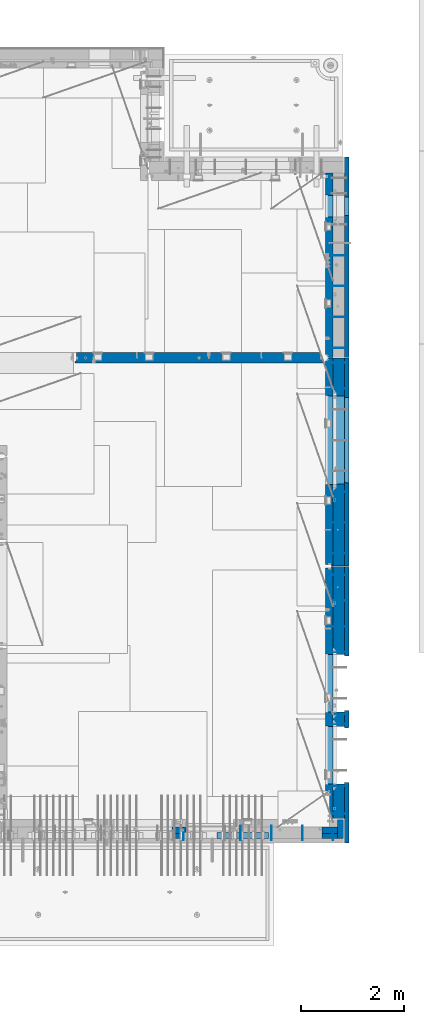
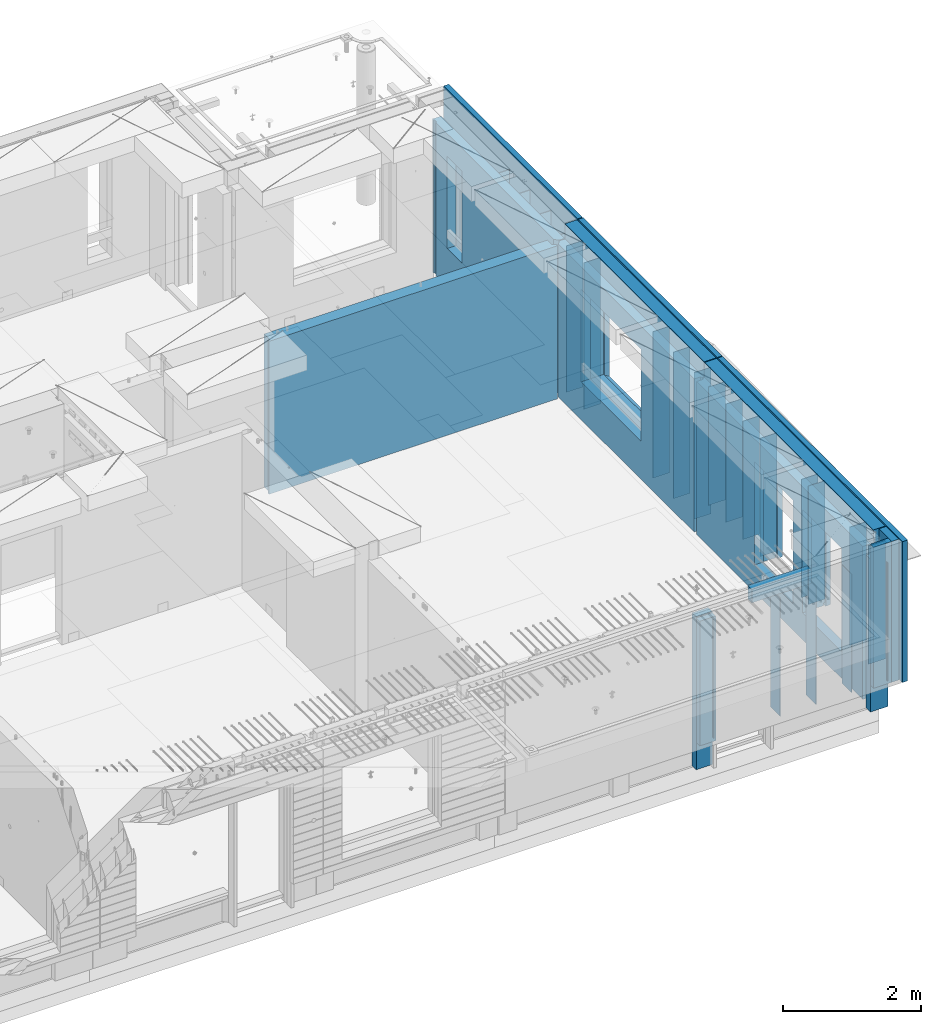
# One storey, part 221 of 325: 38 walls, 7 elements without a shape of their own.
"""IFC2X3 building model written with IfcOpenShell, lengths in millimetres."""

from ifc_helpers import new_model, si_unit, frame, origin_with_axes, place, context, subcontext, project, spatial, faceted_brep, material, type_object, element, aggregate, save


model = new_model("IFC2X3")

# Units and contexts
model_context = context("Model", 3, precision=1e-05, world=origin_with_axes())
body_context = subcontext(model_context, "Body", "Model", "MODEL_VIEW")
ifc_project = project(units=[si_unit("LENGTHUNIT", "METRE", prefix="MILLI"), si_unit("AREAUNIT", "SQUARE_METRE"), si_unit("VOLUMEUNIT", "CUBIC_METRE"), si_unit("MASSUNIT", "GRAM", prefix="KILO"), si_unit("TIMEUNIT", "SECOND"), si_unit("PLANEANGLEUNIT", "RADIAN"), si_unit("SOLIDANGLEUNIT", "STERADIAN"), si_unit("THERMODYNAMICTEMPERATUREUNIT", "DEGREE_CELSIUS"), si_unit("LUMINOUSINTENSITYUNIT", "LUMEN")], contexts=[model_context])

# Site, building, storey
site_placement = place(None, origin_with_axes())
site = spatial("IfcSite", under=ifc_project, at=site_placement, CompositionType="ELEMENT")
building_placement = place(site_placement, origin_with_axes())
building = spatial("IfcBuilding", under=site, at=building_placement, CompositionType="ELEMENT")
storey_placement = place(building_placement, origin_with_axes())
storey = spatial("IfcBuildingStorey", under=building, at=storey_placement, Name="1", CompositionType="ELEMENT", Elevation=0.0)

# Assembly, walls
assembly_1_placement = place(storey_placement, origin_with_axes())
assembly_1 = element("IfcElementAssembly", 1, at=assembly_1_placement, inside=storey, AssemblyPlace="NOTDEFINED", PredefinedType="REINFORCEMENT_UNIT")
ifc_material_1 = material(Name="Undefined")
wall_type_1 = type_object("IfcWallType", PredefinedType="NOTDEFINED")
wall_1_placement = place(assembly_1_placement, frame((35030.0, 13175.0002861023, 83115.0), z_axis=(0.0, 0.0, 1.0), x_axis=(1.0, 0.0, 0.0)))
wall_1 = element("IfcWall", 2, at=wall_1_placement, type_object=wall_type_1, material=ifc_material_1, Name="(PD)", context=body_context, shape_type="Brep", body=[
    faceted_brep([(0.0, 5.0, -1300.0), (0.0, 5.0, 1300.0), (280.0, 5.0, 1300.0), (280.0, 5.0, -1300.0), (0.0, -5.0, 1300.0), (280.0, -5.0, 1300.0), (0.0, -5.0, -1300.0), (280.0, -5.0, -1300.0)], [[[0, 1, 2, 3]], [[1, 4, 5, 2]], [[4, 6, 7, 5]], [[6, 0, 3, 7]], [[5, 7, 3, 2]], [[6, 4, 1, 0]]]),
])
wall_2_placement = place(assembly_1_placement, frame((35030.0, 13775.0002861023, 83115.0), z_axis=(0.0, 0.0, 1.0), x_axis=(1.0, 0.0, 0.0)))
wall_2 = element("IfcWall", 3, at=wall_2_placement, type_object=wall_type_1, material=ifc_material_1, Name="(PD)", context=body_context, shape_type="Brep", body=[
    faceted_brep([(0.0, 5.0, -1300.0), (0.0, 5.0, 1300.0), (280.0, 5.0, 1300.0), (280.0, 5.0, -1300.0), (0.0, -5.0, 1300.0), (280.0, -5.0, 1300.0), (0.0, -5.0, -1300.0), (280.0, -5.0, -1300.0)], [[[0, 1, 2, 3]], [[1, 4, 5, 2]], [[4, 6, 7, 5]], [[6, 0, 3, 7]], [[5, 7, 3, 2]], [[6, 4, 1, 0]]]),
])
wall_3_placement = place(assembly_1_placement, frame((35030.0, 16885.0002861023, 83115.0), z_axis=(0.0, 0.0, 1.0), x_axis=(1.0, 0.0, 0.0)))
wall_3 = element("IfcWall", 4, at=wall_3_placement, type_object=wall_type_1, material=ifc_material_1, Name="(PD)", context=body_context, shape_type="Brep", body=[
    faceted_brep([(0.0, 5.0, -1300.0), (0.0, 5.0, 1300.0), (280.0, 5.0, 1300.0), (280.0, 5.0, -1300.0), (0.0, -5.0, 1300.0), (280.0, -5.0, 1300.0), (0.0, -5.0, -1300.0), (280.0, -5.0, -1300.0)], [[[0, 1, 2, 3]], [[1, 4, 5, 2]], [[4, 6, 7, 5]], [[6, 0, 3, 7]], [[5, 7, 3, 2]], [[6, 4, 1, 0]]]),
])
wall_4_placement = place(assembly_1_placement, frame((35030.0, 16385.0002861023, 83115.0), z_axis=(0.0, 0.0, 1.0), x_axis=(1.0, 0.0, 0.0)))
wall_4 = element("IfcWall", 5, at=wall_4_placement, type_object=wall_type_1, material=ifc_material_1, Name="(PD)", context=body_context, shape_type="Brep", body=[
    faceted_brep([(0.0, 5.0, -1300.0), (0.0, 5.0, 1300.0), (280.0, 5.0, 1300.0), (280.0, 5.0, -1300.0), (0.0, -5.0, 1300.0), (280.0, -5.0, 1300.0), (0.0, -5.0, -1300.0), (280.0, -5.0, -1300.0)], [[[0, 1, 2, 3]], [[1, 4, 5, 2]], [[4, 6, 7, 5]], [[6, 0, 3, 7]], [[5, 7, 3, 2]], [[6, 4, 1, 0]]]),
])

assembly_2_placement = place(storey_placement, origin_with_axes())
assembly_2 = element("IfcElementAssembly", 6, at=assembly_2_placement, inside=storey, AssemblyPlace="NOTDEFINED", PredefinedType="REINFORCEMENT_UNIT")
wall_5_placement = place(assembly_2_placement, frame((35030.0, 17175.0002441406, 83115.0), z_axis=(0.0, 0.0, 1.0), x_axis=(1.0, 0.0, 0.0)))
wall_5 = element("IfcWall", 7, at=wall_5_placement, type_object=wall_type_1, material=ifc_material_1, Name="(PD)", context=body_context, shape_type="Brep", body=[
    faceted_brep([(0.0, 5.0, -1300.0), (0.0, 5.0, 1300.0), (280.0, 5.0, 1300.0), (280.0, 5.0, -1300.0), (0.0, -5.0, 1300.0), (280.0, -5.0, 1300.0), (0.0, -5.0, -1300.0), (280.0, -5.0, -1300.0)], [[[0, 1, 2, 3]], [[1, 4, 5, 2]], [[4, 6, 7, 5]], [[6, 0, 3, 7]], [[5, 7, 3, 2]], [[6, 4, 1, 0]]]),
])
wall_6_placement = place(assembly_2_placement, frame((35030.0, 17775.0002441406, 83115.0), z_axis=(0.0, 0.0, 1.0), x_axis=(1.0, 0.0, 0.0)))
wall_6 = element("IfcWall", 8, at=wall_6_placement, type_object=wall_type_1, material=ifc_material_1, Name="(PD)", context=body_context, shape_type="Brep", body=[
    faceted_brep([(0.0, 5.0, -1300.0), (0.0, 5.0, 1300.0), (280.0, 5.0, 1300.0), (280.0, 5.0, -1300.0), (0.0, -5.0, 1300.0), (280.0, -5.0, 1300.0), (0.0, -5.0, -1300.0), (280.0, -5.0, -1300.0)], [[[0, 1, 2, 3]], [[1, 4, 5, 2]], [[4, 6, 7, 5]], [[6, 0, 3, 7]], [[5, 7, 3, 2]], [[6, 4, 1, 0]]]),
])
wall_7_placement = place(assembly_2_placement, frame((35030.0, 18375.0002441406, 83115.0), z_axis=(0.0, 0.0, 1.0), x_axis=(1.0, 0.0, 0.0)))
wall_7 = element("IfcWall", 9, at=wall_7_placement, type_object=wall_type_1, material=ifc_material_1, Name="(PD)", context=body_context, shape_type="Brep", body=[
    faceted_brep([(0.0, 5.0, -1300.0), (0.0, 5.0, 1300.0), (280.0, 5.0, 1300.0), (280.0, 5.0, -1300.0), (0.0, -5.0, 1300.0), (280.0, -5.0, 1300.0), (0.0, -5.0, -1300.0), (280.0, -5.0, -1300.0)], [[[0, 1, 2, 3]], [[1, 4, 5, 2]], [[4, 6, 7, 5]], [[6, 0, 3, 7]], [[5, 7, 3, 2]], [[6, 4, 1, 0]]]),
])
wall_8_placement = place(assembly_2_placement, frame((35030.0, 18975.0002441406, 83115.0), z_axis=(0.0, 0.0, 1.0), x_axis=(1.0, 0.0, 0.0)))
wall_8 = element("IfcWall", 10, at=wall_8_placement, type_object=wall_type_1, material=ifc_material_1, Name="(PD)", context=body_context, shape_type="Brep", body=[
    faceted_brep([(0.0, 5.0, -1300.0), (0.0, 5.0, 1300.0), (280.0, 5.0, 1300.0), (280.0, 5.0, -1300.0), (0.0, -5.0, 1300.0), (280.0, -5.0, 1300.0), (0.0, -5.0, -1300.0), (280.0, -5.0, -1300.0)], [[[0, 1, 2, 3]], [[1, 4, 5, 2]], [[4, 6, 7, 5]], [[6, 0, 3, 7]], [[5, 7, 3, 2]], [[6, 4, 1, 0]]]),
])

# Wall
wall_9_placement = place(assembly_1_placement, frame((35030.0, 14375.0002861023, 83115.0), z_axis=(0.0, 0.0, 1.0), x_axis=(1.0, 0.0, 0.0)))
wall_9 = element("IfcWall", 11, at=wall_9_placement, type_object=wall_type_1, material=ifc_material_1, Name="(PD)", context=body_context, shape_type="Brep", body=[
    faceted_brep([(0.0, 5.0, -1300.0), (0.0, 5.0, 1300.0), (280.0, 5.0, 1300.0), (280.0, 5.0, -1300.0), (0.0, -5.0, 1300.0), (280.0, -5.0, 1300.0), (0.0, -5.0, -1300.0), (280.0, -5.0, -1300.0)], [[[0, 1, 2, 3]], [[1, 4, 5, 2]], [[4, 6, 7, 5]], [[6, 0, 3, 7]], [[5, 7, 3, 2]], [[6, 4, 1, 0]]]),
])

# Assembly, wall
assembly_3_placement = place(storey_placement, origin_with_axes())
assembly_3 = element("IfcElementAssembly", 12, at=assembly_3_placement, inside=storey, AssemblyPlace="NOTDEFINED", PredefinedType="REINFORCEMENT_UNIT")
ifc_material_2 = material(Name="CONCRETE/C25/30")
wall_type_2 = type_object("IfcWallType", PredefinedType="NOTDEFINED")
wall_10_placement = place(assembly_3_placement, frame((30040.0, 16980.0002441406, 83112.5), z_axis=(0.0, 0.0, 1.0), x_axis=(1.0, 0.0, 0.0)))
wall_10 = element("IfcWall", 13, at=wall_10_placement, type_object=wall_type_2, material=ifc_material_2, context=body_context, shape_type="Brep", body=[
    faceted_brep([(4785.0, 100.0, 1357.5), (4785.0, -30.0, 1357.5), (4785.0, -30.0, -1357.5), (4785.0, 100.0, -1357.5), (4840.0, -60.0, 1357.5), (4840.0, -60.0, -1357.5), (30.0003214753524, 100.0, 1357.5), (30.0003214753524, 100.0, -1357.5), (30.0003214753524, -57.0, -1357.5), (30.0003214753524, -57.0, 1357.5), (0.0, -70.0001393059865, -1357.5), (0.0, -70.0001393059865, 1357.5), (0.0, -100.0, -1357.5), (0.0, -100.0, 1357.5), (4840.0, -100.0, -1357.5), (4840.0, -100.0, 1357.5)], [[[0, 1, 2, 3]], [[4, 5, 2, 1]], [[6, 7, 8, 9]], [[9, 8, 10, 11]], [[12, 13, 11, 10]], [[13, 12, 14, 15]], [[0, 6, 9, 11, 13, 15, 4, 1]], [[7, 6, 0, 3]], [[14, 12, 10, 8, 7, 3, 2, 5]], [[15, 14, 5, 4]]]),
])
aggregate(assembly_3, [wall_10])

# Assemblies, wall
assembly_4_placement = place(storey_placement, origin_with_axes())
assembly_4 = element("IfcElementAssembly", 14, at=assembly_4_placement, inside=storey, AssemblyPlace="NOTDEFINED", PredefinedType="REINFORCEMENT_UNIT")
assembly_5_placement = place(assembly_4_placement, origin_with_axes())
assembly_5 = element("IfcElementAssembly", 15, at=assembly_5_placement, Name="Steel Assembly", AssemblyPlace="NOTDEFINED", PredefinedType="NOTDEFINED")
aggregate(assembly_4, [assembly_5])
ifc_material_3 = material()
wall_type_3 = type_object("IfcWallType", PredefinedType="NOTDEFINED")
wall_11_placement = place(assembly_5_placement, frame((32799.9998568133, 7690.00021946163, 84590.0), z_axis=(0.0, 0.0, 1.0), x_axis=(1.0, 0.0, 0.0)))
wall_11 = element("IfcWall", 16, at=wall_11_placement, type_object=wall_type_3, material=ifc_material_3, context=body_context, shape_type="Brep", body=[
    faceted_brep([(0.0, 60.0, -120.0), (0.0, 60.0, 120.0), (1000.0, 60.0, 120.0), (1000.0, 60.0, -120.0), (0.0, -60.0, 120.0), (1000.0, -60.0, 120.0), (0.0, -60.0, -120.0), (1000.0, -60.0, -120.0)], [[[0, 1, 2, 3]], [[1, 4, 5, 2]], [[4, 6, 7, 5]], [[6, 0, 3, 7]], [[5, 7, 3, 2]], [[6, 4, 1, 0]]]),
])
aggregate(assembly_5, [wall_11])

# Assembly, wall
assembly_6_placement = place(storey_placement, origin_with_axes())
assembly_6 = element("IfcElementAssembly", 17, at=assembly_6_placement, inside=storey, AssemblyPlace="NOTDEFINED", PredefinedType="REINFORCEMENT_UNIT")
ifc_material_4 = material(Name="COS5gt")
wall_type_4 = type_object("IfcWallType", PredefinedType="NOTDEFINED")
wall_12_placement = place(assembly_6_placement, frame((35170.0, 12920.0002861023, 83247.5), z_axis=(0.0, 0.0, 1.0), x_axis=(0.0, -1.0, 0.0)))
wall_12 = element("IfcWall", 18, at=wall_12_placement, type_object=wall_type_4, material=ifc_material_4, context=body_context, shape_type="Brep", body=[
    faceted_brep([(4905.00028610229, 110.0, -957.5), (4905.00028610229, 90.0, -957.5), (4225.54078387356, 90.0, -957.5), (4225.00024333302, 110.0, -957.5), (-0.25, 110.0, 1442.5), (-0.25, 90.0, 1442.5), (4905.00028610229, 90.0, 1442.5), (4905.00028610229, 110.0, 1442.5), (0.0, 90.0, 1492.5), (4905.00028610229, 90.0, 1492.5), (0.0, -110.0, 1492.5), (4905.00028610229, -110.0, 1492.5), (4905.00028610229, -110.0, -1007.5), (4905.00028610229, 90.0, -1007.5), (4225.54078387356, 90.0, -1007.5), (4230.94618927897, -110.0, -1007.5), (4230.94618927897, -110.0, 813.445945945947), (4225.00024333302, 110.0, 807.5), (3109.05429738708, -110.0, 813.445945945947), (3115.00024333302, 110.0, 807.5), (2825.00062480275, 110.0, 807.5), (2830.9465707487, -110.0, 813.445945945947), (1709.0546788568, -110.0, 813.445945945947), (1715.00062480275, 110.0, 807.5), (2825.00062480275, 110.0, -957.5), (2825.54116534329, 90.0, -957.5), (2825.54116534329, 90.0, -1007.5), (2830.9465707487, -110.0, -1007.5), (3115.00024333302, 110.0, -957.5), (3114.45970279248, 90.0, -957.5), (3114.45970279248, 90.0, -1007.5), (3109.05429738708, -110.0, -1007.5), (1715.00062480275, 110.0, -957.5), (-0.25, 110.0, -957.5), (-0.25, 90.0, -957.5), (1714.46008426221, 90.0, -957.5), (-0.25, 90.0, -1007.5), (0.0, -110.0, -1007.5), (1709.0546788568, -110.0, -1007.5), (1714.46008426221, 90.0, -1007.5)], [[[0, 1, 2, 3]], [[4, 5, 6, 7]], [[8, 9, 6, 5]], [[10, 11, 9, 8]], [[1, 0, 7, 6, 9, 11, 12, 13]], [[2, 1, 13, 14]], [[12, 15, 14, 13]], [[16, 17, 3, 2, 14, 15]], [[17, 16, 18, 19]], [[20, 21, 22, 23]], [[21, 20, 24, 25, 26, 27]], [[25, 24, 28, 29]], [[25, 29, 30, 26]], [[31, 27, 26, 30]], [[29, 28, 19, 18, 31, 30]], [[24, 20, 23, 32, 33, 4, 7, 0, 3, 17, 19, 28]], [[34, 33, 32, 35]], [[10, 8, 5, 4, 33, 34, 36, 37]], [[22, 21, 27, 31, 18, 16, 15, 12, 11, 10, 37, 38]], [[35, 32, 23, 22, 38, 39]], [[34, 35, 39, 36]], [[38, 37, 36, 39]]]),
])

# Wall
wall_13_placement = place(assembly_1_placement, frame((35170.0, 16980.0002861023, 83247.5), z_axis=(0.0, 0.0, 1.0), x_axis=(0.0, -1.0, 0.0)))
wall_13 = element("IfcWall", 19, at=wall_13_placement, type_object=wall_type_4, material=ifc_material_4, context=body_context, shape_type="Brep", body=[
    faceted_brep([(1409.0, 90.0, -1492.5), (1409.0, 90.0, -1442.5), (4045.0, 90.0, -1442.5), (4045.0, 90.0, -1492.5), (5.0, 110.0, -1492.5), (5.0, -110.0, -1492.5), (5.0, -110.0, 1492.5), (5.00004196166992, 90.0, 1492.5), (5.00004196166992, 90.0, 1442.5), (5.00004196166992, 110.0, 1442.5), (4045.0, -110.0, -1492.5), (4045.0, -110.0, 1492.5), (2460.94588410319, -110.0, -813.445945945947), (739.053992211293, -110.0, -813.445945945947), (739.053992211293, -110.0, 813.445945945947), (2460.94588410319, -110.0, 813.445945945947), (2454.99993815724, 110.0, 807.5), (744.99993815724, 110.0, 807.5), (2454.99993815724, 110.0, -802.5), (2454.99993815724, 110.0, -807.5), (2424.99993815724, 110.0, -807.5), (774.99993815724, 110.0, -807.5), (744.99993815724, 110.0, -807.5), (744.99993815724, 110.0, -802.5), (4045.0, 110.0, 1442.5), (4045.0, 110.0, -1442.5), (1409.0, 110.0, -1442.5), (1409.0, 110.0, -1492.5), (4045.0, 90.0, 1442.5), (4045.0, 90.0, 1492.5)], [[[0, 1, 2, 3]], [[4, 5, 6, 7, 8, 9]], [[6, 5, 10, 11], [12, 13, 14, 15]], [[16, 15, 14, 17]], [[18, 19, 12, 15, 16]], [[20, 21, 22, 13, 12, 19]], [[23, 17, 14, 13, 22]], [[4, 9, 24, 25, 26, 27], [22, 21, 20, 19, 18, 16, 17, 23]], [[3, 10, 5, 4, 27, 0]], [[26, 1, 0, 27]], [[25, 2, 1, 26]], [[24, 28, 29, 11, 10, 3, 2, 25]], [[9, 8, 28, 24]], [[7, 29, 28, 8]], [[6, 11, 29, 7]]]),
])

ifc_material_5 = material(Name="CONCRETE/C30/37")
wall_type_5 = type_object("IfcWallType", PredefinedType="NOTDEFINED")
wall_14_placement = place(assembly_6_placement, frame((35322.5, 12920.2502861023, 83247.5), z_axis=(0.0, 0.0, 1.0), x_axis=(0.0, -1.0, 0.0)))
wall_14 = element("IfcWall", 20, at=wall_14_placement, type_object=wall_type_5, material=ifc_material_5, context=body_context, shape_type="Brep", body=[
    faceted_brep([(1745.25062480275, 42.5, 782.5), (2795.25062480275, 42.5, 782.5), (2805.25062480275, 42.5, 782.5), (2795.25062480275, -42.5, 787.5), (1745.25062480275, -42.5, 787.5), (1735.25062480275, 42.5, 782.5), (2795.25062480275, -42.5, 782.5), (2805.25062480275, 42.5, -1007.5), (2795.25062480275, -42.5, -1007.5), (3145.25024333302, -42.5, -1007.5), (3135.25024333302, 42.5, -1007.5), (3135.25024333302, 42.5, 782.5), (3145.25024333302, -42.5, 787.5), (3145.25024333302, -42.5, 782.5), (3145.25024333302, 42.5, 782.5), (4195.25024333302, 42.5, 782.5), (4205.25024333302, 42.5, 782.5), (4195.25024333302, -42.5, 787.5), (4195.25024333302, -42.5, 782.5), (4205.25024333302, 42.5, -1007.5), (4195.25024333302, -42.5, -1007.5), (5375.25028610229, -42.5, -1007.5), (5375.25028610229, 42.5, -1007.5), (5375.25028610229, 42.5, 1492.5), (5375.25028610229, -42.5, 1492.5), (0.0, 42.5, 1492.5), (0.0, -42.5, 1492.5), (0.0, 42.5, -1007.5), (0.0, -42.5, -1007.5), (1745.25062480275, -42.5, 782.5), (1745.25062480275, -42.5, -1007.5), (1735.25062480275, 42.5, -1007.5)], [[[0, 1, 2, 3, 4, 5]], [[6, 3, 2, 7, 8]], [[9, 8, 7, 10]], [[11, 12, 13, 9, 10]], [[14, 15, 16, 17, 12, 11]], [[18, 17, 16, 19, 20]], [[21, 20, 19, 22]], [[23, 24, 21, 22]], [[25, 26, 24, 23]], [[26, 25, 27, 28]], [[29, 4, 3, 6, 8, 9, 13, 12, 17, 18, 20, 21, 24, 26, 28, 30]], [[5, 4, 29, 30, 31]], [[25, 23, 22, 19, 16, 15, 14, 11, 10, 7, 2, 1, 0, 5, 31, 27]], [[30, 28, 27, 31]]]),
])

wall_15_placement = place(assembly_1_placement, frame((35322.5, 16980.0002861023, 83247.5), z_axis=(0.0, 0.0, 1.0), x_axis=(0.0, -1.0, 0.0)))
wall_15 = element("IfcWall", 21, at=wall_15_placement, type_object=wall_type_5, material=ifc_material_5, context=body_context, shape_type="Brep", body=[
    faceted_brep([(5.00004196166992, 42.5, 1492.5), (5.00004196166992, -42.5, 1492.5), (4045.0, -42.5, 1492.5), (4045.0, 42.5, 1492.5), (5.00004196166992, -42.5, -1492.5), (5.00004196166992, 42.5, -1492.5), (4045.0, 42.5, -1492.5), (4045.0, -42.5, -1492.5), (2424.99993815724, -42.5, 782.5), (2424.99993815724, -42.5, 781.785034179688), (2424.99993815724, -42.5, -807.5), (774.99993815724, -42.5, -807.5), (774.99993815724, -42.5, 781.785034179688), (774.99993815724, -42.5, 782.5), (774.99993815724, -42.5, 787.5), (2424.99993815724, -42.5, 787.5), (774.99993815724, 42.5, 782.5), (2424.99993815724, 42.5, 782.5), (2434.99993815724, 42.5, 782.5), (764.99993815724, 42.5, 782.5), (2434.99993815724, 42.5, -857.5), (764.99993815724, 42.5, -857.5)], [[[0, 1, 2, 3]], [[4, 5, 6, 7]], [[2, 7, 6, 3]], [[1, 4, 7, 2], [8, 9, 10, 11, 12, 13, 14, 15]], [[16, 17, 18, 15, 14, 19]], [[20, 10, 9, 8, 15, 18]], [[21, 11, 10, 20]], [[19, 14, 13, 12, 11, 21]], [[5, 0, 3, 6], [20, 18, 17, 16, 19, 21]], [[4, 1, 0, 5]]]),
])

wall_16_placement = place(assembly_2_placement, frame((35322.5, 20432.0002441406, 83247.5), z_axis=(0.0, 0.0, 1.0), x_axis=(0.0, -1.0, 0.0)))
wall_16 = element("IfcWall", 22, at=wall_16_placement, type_object=wall_type_5, material=ifc_material_5, context=body_context, shape_type="Brep", body=[
    faceted_brep([(-453.0, -42.5, -1492.5), (-453.0, -42.5, 1492.5), (-453.0, 42.5, 1492.5), (-453.0, 42.5, -1492.5), (3442.0, 42.5, -1492.5), (3442.0, -42.5, -1492.5), (3442.0, -42.5, 1492.5), (677.000277665298, -42.5, 782.5), (677.000277665298, -42.5, -807.5), (327.000277665298, -42.5, -807.5), (327.000277665298, -42.5, 782.5), (327.000277665298, -42.5, 787.5), (677.000277665298, -42.5, 787.5), (327.000277665298, 42.5, 782.5), (677.000277665298, 42.5, 782.5), (687.000277665298, 42.5, 782.5), (317.000277665298, 42.5, 782.5), (687.000277665298, 42.5, -857.5), (317.000277665298, 42.5, -857.5), (3442.0, 42.5, 1492.5)], [[[0, 1, 2, 3]], [[0, 3, 4, 5]], [[1, 0, 5, 6], [7, 8, 9, 10, 11, 12]], [[13, 14, 15, 12, 11, 16]], [[17, 8, 7, 12, 15]], [[18, 9, 8, 17]], [[16, 11, 10, 9, 18]], [[3, 2, 19, 4], [17, 15, 14, 13, 16, 18]], [[6, 5, 4, 19]], [[2, 1, 6, 19]]]),
])

wall_type_6 = type_object("IfcWallType", PredefinedType="NOTDEFINED")
wall_17_placement = place(assembly_6_placement, frame((34985.0, 12920.0002861023, 83112.5), z_axis=(0.0, 0.0, 1.0), x_axis=(0.0, -1.0, 0.0)))
wall_17 = element("IfcWall", 23, at=wall_17_placement, type_object=wall_type_6, material=ifc_material_2, context=body_context, shape_type="Brep", body=[
    faceted_brep([(4855.00028610229, -75.0, 1357.5), (4855.00028610229, -75.0, -1357.5), (4855.00028610229, 32.0000069488524, -1357.5), (4855.00028610229, 32.0000069488524, 1357.5), (4905.00028610229, 45.0000069488524, 1357.5), (4905.00028610229, 45.0000069488524, -1357.5), (29.9999989126591, 32.0000004547946, 1357.5), (29.9999989126591, 32.0000004547946, -1357.5), (30.0000016637459, -75.0, -1357.5), (30.0000016637459, -75.0, 1357.5), (0.0, 45.0, 1357.5), (0.0, 45.0, -1357.5), (0.0, 75.0, 1357.5), (0.0, 75.0, -1357.5), (4905.00028610229, 75.0, -1357.5), (4905.00028610229, 75.0, 1357.5), (4230.94618927897, 75.0, 948.445945945947), (4235.00024333302, -75.0, 952.5), (3105.00024333302, -75.0, 952.5), (3109.05429738708, 75.0, 948.445945945947), (4230.94618927897, 75.0, -878.445945945947), (4235.00024333302, -75.0, -882.5), (3109.05429738708, 75.0, -878.445945945947), (3105.00024333302, -75.0, -882.5), (2830.9465707487, 75.0, -878.445945945947), (2830.9465707487, 75.0, 948.445945945947), (1709.0546788568, 75.0, 948.445945945947), (1709.0546788568, 75.0, -878.445945945947), (2835.00062480275, -75.0, -882.5), (2835.00062480275, -75.0, 952.5), (1705.00062480275, -75.0, -882.5), (1705.00062480275, -75.0, 952.5)], [[[0, 1, 2, 3]], [[4, 3, 2, 5]], [[6, 7, 8, 9]], [[10, 11, 7, 6]], [[12, 13, 11, 10]], [[1, 8, 7, 11, 13, 14, 5, 2]], [[14, 15, 4, 5]], [[16, 17, 18, 19]], [[20, 21, 17, 16]], [[22, 23, 21, 20]], [[19, 18, 23, 22]], [[13, 12, 15, 14], [20, 16, 19, 22], [24, 25, 26, 27]], [[24, 28, 29, 25]], [[27, 30, 28, 24]], [[26, 31, 30, 27]], [[25, 29, 31, 26]], [[9, 8, 1, 0], [28, 30, 31, 29], [21, 23, 18, 17]], [[15, 12, 10, 6, 9, 0, 3, 4]]]),
])

wall_18_placement = place(assembly_1_placement, frame((34985.0, 16980.0002861023, 83112.5), z_axis=(0.0, 0.0, 1.0), x_axis=(0.0, -1.0, 0.0)))
wall_18 = element("IfcWall", 24, at=wall_18_placement, type_object=wall_type_6, material=ifc_material_2, context=body_context, shape_type="Brep", body=[
    faceted_brep([(5.0, 75.0, -1357.5), (5.0, 75.0, 1357.5), (4045.0, 75.0, 1357.5), (4045.0, 75.0, -1357.5), (2460.94588410319, 75.0, -678.445945945947), (2460.94588410319, 75.0, 948.445945945947), (739.053992211293, 75.0, 948.445945945947), (739.053992211293, 75.0, -678.445945945947), (5.0, -15.0000022791291, -1357.5), (5.0, -15.0000022791291, 1357.5), (65.0, -75.0, 1357.5), (65.0, -75.0, -1357.5), (4015.0, -75.0, 1357.5), (4015.0, 32.0, 1357.5), (4045.0, 45.0, 1357.5), (4045.0, 45.0, -1357.5), (4015.0, -75.0, -1357.5), (4015.0, 32.0, -1357.5), (2464.99993815724, -75.0, -682.5), (734.99993815724, -75.0, -682.5), (734.99993815724, -75.0, 952.5), (2464.99993815724, -75.0, 952.5)], [[[0, 1, 2, 3], [4, 5, 6, 7]], [[1, 0, 8, 9]], [[10, 9, 8, 11]], [[2, 1, 9, 10, 12, 13, 14]], [[3, 2, 14, 15]], [[16, 11, 8, 0, 3, 15, 17]], [[14, 13, 17, 15]], [[12, 16, 17, 13]], [[10, 11, 16, 12], [18, 19, 20, 21]], [[6, 20, 19, 7]], [[5, 21, 20, 6]], [[4, 18, 21, 5]], [[7, 19, 18, 4]]]),
])

aggregate(assembly_1, [wall_1, wall_2, wall_3, wall_4, wall_9, wall_13, wall_15, wall_18])

wall_19_placement = place(assembly_2_placement, frame((34985.0, 20575.0002441406, 83112.5), z_axis=(0.0, 0.0, 1.0), x_axis=(0.0, -1.0, 0.0)))
wall_19 = element("IfcWall", 25, at=wall_19_placement, type_object=wall_type_6, material=ifc_material_2, context=body_context, shape_type="Brep", body=[
    faceted_brep([(0.0, 75.0, -1357.5), (0.0, 75.0, 1357.5), (3585.0, 75.0, 1357.5), (3585.0, 75.0, -1357.5), (855.946223611245, 75.0, -678.445945945947), (855.946223611245, 75.0, 948.445945945947), (434.054331719351, 75.0, 948.445945945947), (434.054331719351, 75.0, -678.445945945947), (0.0, -75.0, -1357.5), (0.0, -75.0, 1357.5), (30.0050569130617, -75.0, -1357.5), (30.0050569130617, -75.0, 1357.5), (43.0050569130617, -55.0, -1357.5), (43.0050569130617, -55.0, 1357.5), (97.0050569130617, -55.0, -1357.5), (97.0050569130617, -55.0, 1357.5), (110.005056913062, -75.0, -1357.5), (110.005056913062, -75.0, 1357.5), (3525.0, -75.0, 1357.5), (3585.0, -15.0, 1357.5), (3585.0, -15.0, -1357.5), (3525.0, -75.0, -1357.5), (860.000277665298, -75.0, -682.5), (430.000277665298, -75.0, -682.5), (430.000277665298, -75.0, 952.5), (860.000277665298, -75.0, 952.5)], [[[0, 1, 2, 3], [4, 5, 6, 7]], [[8, 9, 1, 0]], [[9, 8, 10, 11]], [[11, 10, 12, 13]], [[13, 12, 14, 15]], [[15, 14, 16, 17]], [[2, 1, 9, 11, 13, 15, 17, 18, 19]], [[3, 2, 19, 20]], [[16, 14, 12, 10, 8, 0, 3, 20, 21]], [[19, 18, 21, 20]], [[17, 16, 21, 18], [22, 23, 24, 25]], [[6, 24, 23, 7]], [[5, 25, 24, 6]], [[4, 22, 25, 5]], [[7, 23, 22, 4]]]),
])

aggregate(assembly_2, [wall_5, wall_6, wall_7, wall_8, wall_16, wall_19])

# Assembly, walls
assembly_7_placement = place(storey_placement, origin_with_axes())
assembly_7 = element("IfcElementAssembly", 26, at=assembly_7_placement, inside=storey, AssemblyPlace="NOTDEFINED", PredefinedType="REINFORCEMENT_UNIT")
wall_type_7 = type_object("IfcWallType", PredefinedType="NOTDEFINED")
wall_20_placement = place(assembly_7_placement, frame((35060.0, 7780.0, 83365.0), z_axis=(0.0, 0.0, 1.0), x_axis=(0.0, -1.0, 0.0)))
wall_20 = element("IfcWall", 27, at=wall_20_placement, type_object=wall_type_7, material=ifc_material_1, Name="(PD)", context=body_context, shape_type="Brep", body=[
    faceted_brep([(0.0, 5.0, -1050.0), (0.0, 5.0, 1050.0), (180.0, 5.0, 1050.0), (180.0, 5.0, -1050.0), (0.0, -5.0, 1050.0), (180.0, -5.0, 1050.0), (0.0, -5.0, -1050.0), (180.0, -5.0, -1050.0)], [[[0, 1, 2, 3]], [[1, 4, 5, 2]], [[4, 6, 7, 5]], [[6, 0, 3, 7]], [[5, 7, 3, 2]], [[6, 4, 1, 0]]]),
])
wall_21_placement = place(assembly_7_placement, frame((34460.0, 7880.0, 83365.0), z_axis=(0.0, 0.0, 1.0), x_axis=(0.0, -1.0, 0.0)))
wall_21 = element("IfcWall", 28, at=wall_21_placement, type_object=wall_type_7, material=ifc_material_1, Name="(PD)", context=body_context, shape_type="Brep", body=[
    faceted_brep([(0.0, 5.0, -1050.0), (0.0, 5.0, 1050.0), (280.0, 5.0, 1050.0), (280.0, 5.0, -1050.0), (0.0, -5.0, 1050.0), (280.0, -5.0, 1050.0), (0.0, -5.0, -1050.0), (280.0, -5.0, -1050.0)], [[[0, 1, 2, 3]], [[1, 4, 5, 2]], [[4, 6, 7, 5]], [[6, 0, 3, 7]], [[5, 7, 3, 2]], [[6, 4, 1, 0]]]),
])
wall_22_placement = place(assembly_7_placement, frame((33860.0, 7880.0, 83365.0), z_axis=(0.0, 0.0, 1.0), x_axis=(0.0, -1.0, 0.0)))
wall_22 = element("IfcWall", 29, at=wall_22_placement, type_object=wall_type_7, material=ifc_material_1, Name="(PD)", context=body_context, shape_type="Brep", body=[
    faceted_brep([(0.0, 5.0, -1050.0), (0.0, 5.0, 1050.0), (280.0, 5.0, 1050.0), (280.0, 5.0, -1050.0), (0.0, -5.0, 1050.0), (280.0, -5.0, 1050.0), (0.0, -5.0, -1050.0), (280.0, -5.0, -1050.0)], [[[0, 1, 2, 3]], [[1, 4, 5, 2]], [[4, 6, 7, 5]], [[6, 0, 3, 7]], [[5, 7, 3, 2]], [[6, 4, 1, 0]]]),
])
wall_23_placement = place(assembly_7_placement, frame((32144.9998946285, 7780.0, 83365.0), z_axis=(0.0, 0.0, 1.0), x_axis=(0.0, -1.0, 0.0)))
wall_23 = element("IfcWall", 30, at=wall_23_placement, type_object=wall_type_7, material=ifc_material_1, Name="(PD)", context=body_context, shape_type="Brep", body=[
    faceted_brep([(0.0, 5.0, -1050.0), (0.0, 5.0, 1050.0), (180.0, 5.0, 1050.0), (180.0, 5.0, -1050.0), (0.0, -5.0, 1050.0), (180.0, -5.0, 1050.0), (0.0, -5.0, -1050.0), (180.0, -5.0, -1050.0)], [[[0, 1, 2, 3]], [[1, 4, 5, 2]], [[4, 6, 7, 5]], [[6, 0, 3, 7]], [[5, 7, 3, 2]], [[6, 4, 1, 0]]]),
])

# Wall
wall_24_placement = place(assembly_6_placement, frame((35030.0, 12755.0002861023, 83365.0), z_axis=(0.0, 0.0, 1.0), x_axis=(1.0, 0.0, 0.0)))
wall_24 = element("IfcWall", 31, at=wall_24_placement, type_object=wall_type_7, material=ifc_material_1, Name="(PD)", context=body_context, shape_type="Brep", body=[
    faceted_brep([(0.0, 5.0, -1050.0), (0.0, 5.0, 1050.0), (280.0, 5.0, 1050.0), (280.0, 5.0, -1050.0), (0.0, -5.0, 1050.0), (280.0, -5.0, 1050.0), (0.0, -5.0, -1050.0), (280.0, -5.0, -1050.0)], [[[0, 1, 2, 3]], [[1, 4, 5, 2]], [[4, 6, 7, 5]], [[6, 0, 3, 7]], [[5, 7, 3, 2]], [[6, 4, 1, 0]]]),
])

wall_25_placement = place(assembly_6_placement, frame((35030.0, 12255.0002861023, 83365.0), z_axis=(0.0, 0.0, 1.0), x_axis=(1.0, 0.0, 0.0)))
wall_25 = element("IfcWall", 32, at=wall_25_placement, type_object=wall_type_7, material=ifc_material_1, Name="(PD)", context=body_context, shape_type="Brep", body=[
    faceted_brep([(0.0, 5.0, -1050.0), (0.0, 5.0, 1050.0), (280.0, 5.0, 1050.0), (280.0, 5.0, -1050.0), (0.0, -5.0, 1050.0), (280.0, -5.0, 1050.0), (0.0, -5.0, -1050.0), (280.0, -5.0, -1050.0)], [[[0, 1, 2, 3]], [[1, 4, 5, 2]], [[4, 6, 7, 5]], [[6, 0, 3, 7]], [[5, 7, 3, 2]], [[6, 4, 1, 0]]]),
])

wall_26_placement = place(assembly_6_placement, frame((35030.0, 11755.0002861023, 83365.0), z_axis=(0.0, 0.0, 1.0), x_axis=(1.0, 0.0, 0.0)))
wall_26 = element("IfcWall", 33, at=wall_26_placement, type_object=wall_type_7, material=ifc_material_1, Name="(PD)", context=body_context, shape_type="Brep", body=[
    faceted_brep([(0.0, 5.0, -1050.0), (0.0, 5.0, 1050.0), (280.0, 5.0, 1050.0), (280.0, 5.0, -1050.0), (0.0, -5.0, 1050.0), (280.0, -5.0, 1050.0), (0.0, -5.0, -1050.0), (280.0, -5.0, -1050.0)], [[[0, 1, 2, 3]], [[1, 4, 5, 2]], [[4, 6, 7, 5]], [[6, 0, 3, 7]], [[5, 7, 3, 2]], [[6, 4, 1, 0]]]),
])

wall_27_placement = place(assembly_6_placement, frame((35030.0, 11255.0002861023, 83365.0), z_axis=(0.0, 0.0, 1.0), x_axis=(1.0, 0.0, 0.0)))
wall_27 = element("IfcWall", 34, at=wall_27_placement, type_object=wall_type_7, material=ifc_material_1, Name="(PD)", context=body_context, shape_type="Brep", body=[
    faceted_brep([(0.0, 5.0, -1050.0), (0.0, 5.0, 1050.0), (280.0, 5.0, 1050.0), (280.0, 5.0, -1050.0), (0.0, -5.0, 1050.0), (280.0, -5.0, 1050.0), (0.0, -5.0, -1050.0), (280.0, -5.0, -1050.0)], [[[0, 1, 2, 3]], [[1, 4, 5, 2]], [[4, 6, 7, 5]], [[6, 0, 3, 7]], [[5, 7, 3, 2]], [[6, 4, 1, 0]]]),
])

wall_28_placement = place(assembly_6_placement, frame((35030.0, 8105.0, 83365.0), z_axis=(0.0, 0.0, 1.0), x_axis=(1.0, 0.0, 0.0)))
wall_28 = element("IfcWall", 35, at=wall_28_placement, type_object=wall_type_7, material=ifc_material_1, Name="(PD)", context=body_context, shape_type="Brep", body=[
    faceted_brep([(0.0, 5.0, -1050.0), (0.0, 5.0, 1050.0), (280.0, 5.0, 1050.0), (280.0, 5.0, -1050.0), (0.0, -5.0, 1050.0), (280.0, -5.0, 1050.0), (0.0, -5.0, -1050.0), (280.0, -5.0, -1050.0)], [[[0, 1, 2, 3]], [[1, 4, 5, 2]], [[4, 6, 7, 5]], [[6, 0, 3, 7]], [[5, 7, 3, 2]], [[6, 4, 1, 0]]]),
])

wall_29_placement = place(assembly_6_placement, frame((35030.0, 8115.0, 83365.0), z_axis=(0.0, 0.0, 1.0), x_axis=(1.0, 0.0, 0.0)))
wall_29 = element("IfcWall", 36, at=wall_29_placement, type_object=wall_type_7, material=ifc_material_1, Name="(PD)", context=body_context, shape_type="Brep", body=[
    faceted_brep([(0.0, 5.0, -1050.0), (0.0, 5.0, 1050.0), (280.0, 5.0, 1050.0), (280.0, 5.0, -1050.0), (0.0, -5.0, 1050.0), (280.0, -5.0, 1050.0), (0.0, -5.0, -1050.0), (280.0, -5.0, -1050.0)], [[[0, 1, 2, 3]], [[1, 4, 5, 2]], [[4, 6, 7, 5]], [[6, 0, 3, 7]], [[5, 7, 3, 2]], [[6, 4, 1, 0]]]),
])

wall_30_placement = place(assembly_6_placement, frame((35030.0, 9855.00028610229, 83365.0), z_axis=(0.0, 0.0, 1.0), x_axis=(1.0, 0.0, 0.0)))
wall_30 = element("IfcWall", 37, at=wall_30_placement, type_object=wall_type_7, material=ifc_material_1, Name="(PD)", context=body_context, shape_type="Brep", body=[
    faceted_brep([(0.0, 5.0, -1050.0), (0.0, 5.0, 1050.0), (280.0, 5.0, 1050.0), (280.0, 5.0, -1050.0), (0.0, -5.0, 1050.0), (280.0, -5.0, 1050.0), (0.0, -5.0, -1050.0), (280.0, -5.0, -1050.0)], [[[0, 1, 2, 3]], [[1, 4, 5, 2]], [[4, 6, 7, 5]], [[6, 0, 3, 7]], [[5, 7, 3, 2]], [[6, 4, 1, 0]]]),
])

wall_31_placement = place(assembly_6_placement, frame((35030.0, 10055.0002861023, 83365.0), z_axis=(0.0, 0.0, 1.0), x_axis=(1.0, 0.0, 0.0)))
wall_31 = element("IfcWall", 38, at=wall_31_placement, type_object=wall_type_7, material=ifc_material_1, Name="(PD)", context=body_context, shape_type="Brep", body=[
    faceted_brep([(0.0, 5.0, -1050.0), (0.0, 5.0, 1050.0), (280.0, 5.0, 1050.0), (280.0, 5.0, -1050.0), (0.0, -5.0, 1050.0), (280.0, -5.0, 1050.0), (0.0, -5.0, -1050.0), (280.0, -5.0, -1050.0)], [[[0, 1, 2, 3]], [[1, 4, 5, 2]], [[4, 6, 7, 5]], [[6, 0, 3, 7]], [[5, 7, 3, 2]], [[6, 4, 1, 0]]]),
])

wall_32_placement = place(assembly_7_placement, frame((33260.0, 7880.0, 83365.0), z_axis=(0.0, 0.0, 1.0), x_axis=(0.0, -1.0, 0.0)))
wall_32 = element("IfcWall", 39, at=wall_32_placement, type_object=wall_type_7, material=ifc_material_1, Name="(PD)", context=body_context, shape_type="Brep", body=[
    faceted_brep([(0.0, 5.0, -1050.0), (0.0, 5.0, 1050.0), (280.0, 5.0, 1050.0), (280.0, 5.0, -1050.0), (0.0, -5.0, 1050.0), (280.0, -5.0, 1050.0), (0.0, -5.0, -1050.0), (280.0, -5.0, -1050.0)], [[[0, 1, 2, 3]], [[1, 4, 5, 2]], [[4, 6, 7, 5]], [[6, 0, 3, 7]], [[5, 7, 3, 2]], [[6, 4, 1, 0]]]),
])

wall_33_placement = place(assembly_6_placement, frame((35030.0, 8655.0, 83365.0), z_axis=(0.0, 0.0, 1.0), x_axis=(1.0, 0.0, 0.0)))
wall_33 = element("IfcWall", 40, at=wall_33_placement, type_object=wall_type_7, material=ifc_material_1, Name="(PD)", context=body_context, shape_type="Brep", body=[
    faceted_brep([(0.0, 5.0, -1050.0), (0.0, 5.0, 1050.0), (280.0, 5.0, 1050.0), (280.0, 5.0, -1050.0), (0.0, -5.0, 1050.0), (280.0, -5.0, 1050.0), (0.0, -5.0, -1050.0), (280.0, -5.0, -1050.0)], [[[0, 1, 2, 3]], [[1, 4, 5, 2]], [[4, 6, 7, 5]], [[6, 0, 3, 7]], [[5, 7, 3, 2]], [[6, 4, 1, 0]]]),
])

aggregate(assembly_6, [wall_24, wall_25, wall_26, wall_27, wall_28, wall_29, wall_30, wall_31, wall_33, wall_14, wall_12, wall_17])

ifc_material_6 = material(Name="SPU")
wall_type_8 = type_object("IfcWallType", PredefinedType="NOTDEFINED")
wall_34_placement = place(assembly_7_placement, frame((35205.0, 8000.0, 83247.5), z_axis=(0.0, 0.0, 1.0), x_axis=(0.0, -1.0, 0.0)))
wall_34 = element("IfcWall", 41, at=wall_34_placement, type_object=wall_type_8, material=ifc_material_6, context=body_context, shape_type="Brep", body=[
    faceted_brep([(0.0, 60.0, 1492.5), (0.0, -60.0, 1492.5), (370.0, -60.0, 1492.5), (370.0, 60.0, 1492.5), (0.0, 60.0, -1007.5), (0.0, -60.0, -1007.5), (370.0, -60.0, -1007.5), (370.0, 60.0, -1007.5)], [[[0, 1, 2, 3]], [[1, 0, 4, 5]], [[2, 1, 5, 6]], [[3, 2, 6, 7]], [[0, 3, 7, 4]], [[6, 5, 4, 7]]]),
])

wall_type_9 = type_object("IfcWallType", PredefinedType="NOTDEFINED")
wall_35_placement = place(assembly_7_placement, frame((32195.0000381475, 7680.0, 83102.5), z_axis=(0.0, 0.0, 1.0), x_axis=(-1.0, 3.00000001838171e-08, 0.0)))
wall_35 = element("IfcWall", 42, at=wall_35_placement, type_object=wall_type_9, material=ifc_material_6, context=body_context, shape_type="Brep", body=[
    faceted_brep([(0.0, 50.0, 1347.5), (0.0, -50.0, 1347.5), (270.001908754726, -50.0, 1347.5), (270.001908754726, 50.0, 1347.5), (0.0, -50.0, -862.5), (270.001908754726, -50.0, -862.5), (270.001908754726, 50.0, -862.5), (0.0, 50.0, -862.5)], [[[0, 1, 2, 3]], [[2, 1, 4, 5]], [[3, 2, 5, 6]], [[0, 3, 6, 7]], [[1, 0, 7, 4]], [[6, 5, 4, 7]]]),
])

ifc_material_7 = material(Name="CONCRETE/C35/45")
wall_type_10 = type_object("IfcWallType", PredefinedType="NOTDEFINED")
wall_36_placement = place(assembly_7_placement, frame((35145.0000381475, 7790.0, 83112.5), z_axis=(0.0, 0.0, 1.0), x_axis=(-1.0, 3.00000001838171e-08, 0.0)))
wall_36 = element("IfcWall", 43, at=wall_36_placement, type_object=wall_type_10, material=ifc_material_7, context=body_context, shape_type="Brep", body=[
    faceted_brep([(0.0, 60.0, -1357.5), (0.0, 60.0, 1357.5), (300.001908754726, 60.0, 1357.5), (300.001908754726, 60.0, -1357.5), (0.0, -60.0, 1357.5), (300.001908754726, -60.0, 1357.5), (0.0, -60.0, -1357.5), (300.001908754726, -60.0, -1357.5)], [[[0, 1, 2, 3]], [[1, 4, 5, 2]], [[4, 6, 7, 5]], [[6, 0, 3, 7]], [[5, 7, 3, 2]], [[6, 4, 1, 0]]]),
])

wall_37_placement = place(assembly_7_placement, frame((32195.0000381475, 7790.0, 83112.5), z_axis=(0.0, 0.0, 1.0), x_axis=(-1.0, 3.00000001838171e-08, 0.0)))
wall_37 = element("IfcWall", 44, at=wall_37_placement, type_object=wall_type_10, material=ifc_material_7, context=body_context, shape_type="Brep", body=[
    faceted_brep([(0.0, 60.0, -1357.5), (0.0, 60.0, 1357.5), (270.001908754726, 60.0, 1357.5), (270.001908754726, 60.0, -1357.5), (0.0, -60.0, 1357.5), (270.001908754726, -60.0, 1357.5), (0.0, -60.0, -1357.5), (270.001908754726, -60.0, -1357.5)], [[[0, 1, 2, 3]], [[1, 4, 5, 2]], [[4, 6, 7, 5]], [[6, 0, 3, 7]], [[5, 7, 3, 2]], [[6, 4, 1, 0]]]),
])

wall_type_11 = type_object("IfcWallType", PredefinedType="NOTDEFINED")
wall_38_placement = place(assembly_7_placement, frame((35145.0000381475, 7680.0, 83247.5), z_axis=(0.0, 0.0, 1.0), x_axis=(-1.0, 3.00000001838171e-08, 0.0)))
wall_38 = element("IfcWall", 45, at=wall_38_placement, type_object=wall_type_11, material=ifc_material_6, context=body_context, shape_type="Brep", body=[
    faceted_brep([(0.0, 50.0, 1492.5), (0.0, -50.0, 1492.5), (300.001908754726, -50.0, 1492.5), (300.001908754726, 50.0, 1492.5), (0.0, -50.0, -1007.5), (300.001908754726, -50.0, -1007.5), (300.001908754726, 50.0, -1007.5), (0.0, 50.0, -1007.5)], [[[0, 1, 2, 3]], [[2, 1, 4, 5]], [[3, 2, 5, 6]], [[0, 3, 6, 7]], [[1, 0, 7, 4]], [[6, 5, 4, 7]]]),
])

aggregate(assembly_7, [wall_38, wall_36, wall_20, wall_21, wall_22, wall_23, wall_34, wall_35, wall_32, wall_37])

save(model, "model.ifc")
